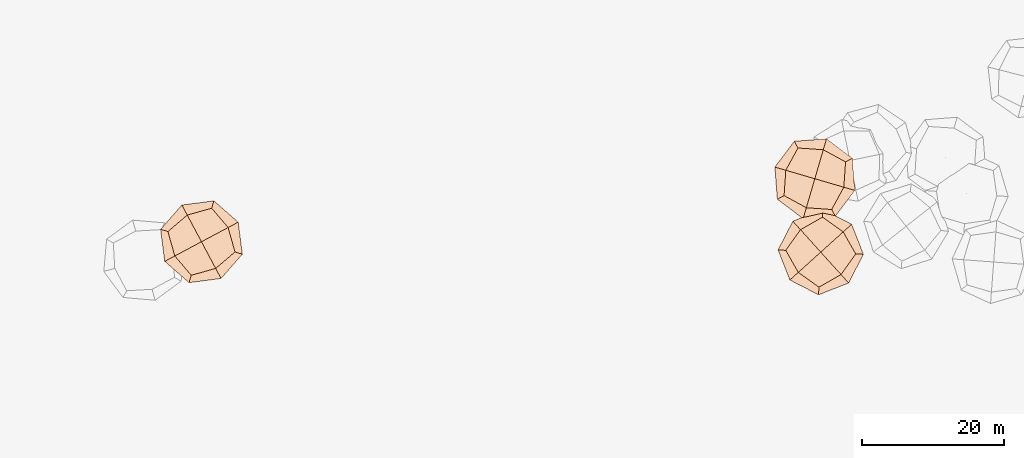
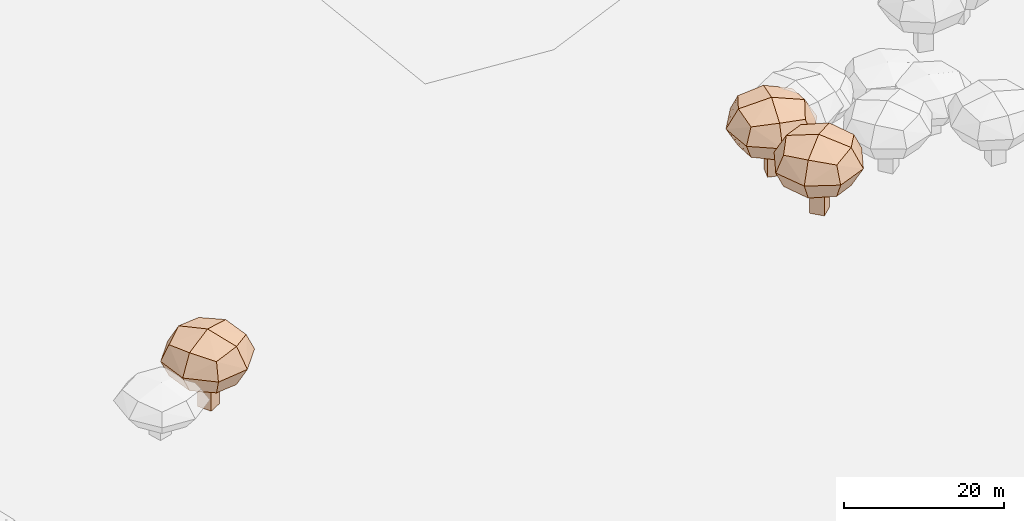
# Not in any storey, part 17 of 92: 3 geographic elements.
"""IFC4 model written with IfcOpenShell, lengths in metres."""

from ifc_helpers import new_model, si_unit, origin_with_axes, place, context, subcontext, project, spatial, triangles, material, element, save


model = new_model("IFC4")

# Units and contexts
model_context = context("Model", 3, precision=1e-05, world=origin_with_axes())
body_context = subcontext(model_context, "Body", "Model", "MODEL_VIEW")
ifc_project = project(units=[si_unit("VOLUMEUNIT", "CUBIC_METRE"), si_unit("LENGTHUNIT", "METRE"), si_unit("AREAUNIT", "SQUARE_METRE")], contexts=[model_context])

# Site
site_placement = place(None, origin_with_axes())
site = spatial("IfcSite", under=ifc_project, at=site_placement)

# Geographic elements
ifc_material = material(Name="tree")
geographic_element_1_placement = place(site_placement, origin_with_axes())
element("IfcGeographicElement", 1, at=geographic_element_1_placement, inside=site, material=ifc_material, Name="cw_instances_tree_210", context=body_context, shape_type="Tessellation", body=[
    triangles([(96.89313110909653, -613.986359858615, 6.803633015926556), (96.89313110909653, -613.986359858615, 6.803633015926556), (96.89313110909653, -613.986359858615, 6.803633015926556), (96.89313110909653, -613.986359858615, 0.0), (96.89313110909653, -613.986359858615, 0.0), (96.89313110909653, -613.986359858615, 0.0), (97.83398614529078, -615.7512371350474, 6.803633015926556), (97.83398614529078, -615.7512371350474, 6.803633015926556), (97.83398614529078, -615.7512371350474, 6.803633015926556), (97.83398614529078, -615.7512371350474, 0.0), (97.83398614529078, -615.7512371350474, 0.0), (97.83398614529078, -615.7512371350474, 0.0), (95.128253832664, -614.9272148948091, 6.803633015926556), (95.128253832664, -614.9272148948091, 6.803633015926556), (95.128253832664, -614.9272148948091, 6.803633015926556), (95.128253832664, -614.9272148948091, 0.0), (95.128253832664, -614.9272148948091, 0.0), (95.128253832664, -614.9272148948091, 0.0), (96.06910886885825, -616.6920921712417, 6.803633015926556), (96.06910886885825, -616.6920921712417, 6.803633015926556), (96.06910886885825, -616.6920921712417, 6.803633015926556), (96.06910886885825, -616.6920921712417, 0.0), (96.06910886885825, -616.6920921712417, 0.0), (96.06910886885825, -616.6920921712417, 0.0), (97.70365412297164, -610.721212612114, 10.134455139926406), (97.70365412297164, -610.721212612114, 10.134455139926406), (97.70365412297164, -610.721212612114, 10.134455139926406), (97.70365412297164, -610.721212612114, 10.134455139926406), (97.70365412297164, -610.721212612114, 10.134455139926406), (97.70365412297164, -610.721212612114, 10.134455139926406), (97.70365410895171, -610.7212120756408, 5.371912219279553), (97.70365410895171, -610.7212120756408, 5.371912219279553), (97.70365410895171, -610.7212120756408, 5.371912219279553), (97.70365410895171, -610.7212120756408, 5.371912219279553), (97.70365410895171, -610.7212120756408, 5.371912219279553), (97.70365410895171, -610.7212120756408, 5.371912219279553), (100.99664617582285, -616.8982814930527, 10.134455139926406), (100.99664617582285, -616.8982814930527, 10.134455139926406), (100.99664617582285, -616.8982814930527, 10.134455139926406), (100.99664617582285, -616.8982814930527, 10.134455139926406), (100.99664617582285, -616.8982814930527, 10.134455139926406), (100.99664617582285, -616.8982814930527, 10.134455139926406), (100.99664617582285, -616.8982814930527, 5.371912219279553), (100.99664617582285, -616.8982814930527, 5.371912219279553), (100.99664617582285, -616.8982814930527, 5.371912219279553), (100.99664617582285, -616.8982814930527, 5.371912219279553), (100.99664617582285, -616.8982814930527, 5.371912219279553), (100.99664617582285, -616.8982814930527, 5.371912219279553), (91.526584056184, -614.0142044812197, 10.134455139926406), (91.526584056184, -614.0142044812197, 10.134455139926406), (91.526584056184, -614.0142044812197, 10.134455139926406), (91.526584056184, -614.0142044812197, 10.134455139926406), (91.526584056184, -614.0142044812197, 10.134455139926406), (91.526584056184, -614.0142044812197, 10.134455139926406), (91.52658447975455, -614.0142042554146, 5.371912219279553), (91.52658447975455, -614.0142042554146, 5.371912219279553), (91.52658447975455, -614.0142042554146, 5.371912219279553), (91.52658447975455, -614.0142042554146, 5.371912219279553), (91.52658447975455, -614.0142042554146, 5.371912219279553), (91.52658447975455, -614.0142042554146, 5.371912219279553), (94.81957623595774, -620.1912741104169, 10.134455139926406), (94.81957623595774, -620.1912741104169, 10.134455139926406), (94.81957623595774, -620.1912741104169, 10.134455139926406), (94.81957623595774, -620.1912741104169, 10.134455139926406), (94.81957623595774, -620.1912741104169, 10.134455139926406), (94.81957623595774, -620.1912741104169, 10.134455139926406), (94.81957612305514, -620.1912738986316, 5.371912219279553), (94.81957612305514, -620.1912738986316, 5.371912219279553), (94.81957612305514, -620.1912738986316, 5.371912219279553), (94.81957612305514, -620.1912738986316, 5.371912219279553), (94.81957612305514, -620.1912738986316, 5.371912219279553), (94.81957612305514, -620.1912738986316, 5.371912219279553), (92.49627184917647, -617.4635454171133, 4.850091157058233), (92.49627184917647, -617.4635454171133, 4.850091157058233), (92.49627184917647, -617.4635454171133, 4.850091157058233), (92.49627184917647, -617.4635454171133, 4.850091157058233), (94.2543131135932, -611.6909001609754, 4.850091157058233), (94.2543131135932, -611.6909001609754, 4.850091157058233), (94.2543131135932, -611.6909001609754, 4.850091157058233), (94.2543131135932, -611.6909001609754, 4.850091157058233), (98.01965599829637, -609.6835980876934, 7.753184087820984), (98.01965599829637, -609.6835980876934, 7.753184087820984), (98.01965599829637, -609.6835980876934, 7.753184087820984), (98.01965599829637, -609.6835980876934, 7.753184087820984), (94.50357393186692, -621.2288883194652, 7.753184087820984), (94.50357393186692, -621.2288883194652, 7.753184087820984), (94.50357393186692, -621.2288883194652, 7.753184087820984), (94.50357393186692, -621.2288883194652, 7.753184087820984), (102.03426081363722, -617.2142841125158, 7.753184087820984), (102.03426081363722, -617.2142841125158, 7.753184087820984), (102.03426081363722, -617.2142841125158, 7.753184087820984), (102.03426081363722, -617.2142841125158, 7.753184087820984), (90.4889701759437, -613.6982022624829, 7.753184087820984), (90.4889701759437, -613.6982022624829, 7.753184087820984), (90.4889701759437, -613.6982022624829, 7.753184087820984), (90.4889701759437, -613.6982022624829, 7.753184087820984), (98.26891751418789, -619.2215864068986, 10.65627579392972), (98.26891751418789, -619.2215864068986, 10.65627579392972), (98.26891751418789, -619.2215864068986, 10.65627579392972), (98.26891751418789, -619.2215864068986, 10.65627579392972), (100.02695846280307, -613.4489407071737, 10.656277392783574), (100.02695846280307, -613.4489407071737, 10.656277392783574), (100.02695846280307, -613.4489407071737, 10.656277392783574), (100.02695846280307, -613.4489407071737, 10.656277392783574), (98.26891724896502, -619.2215860156738, 4.850091157058233), (98.26891724896502, -619.2215860156738, 4.850091157058233), (98.26891724896502, -619.2215860156738, 4.850091157058233), (98.26891724896502, -619.2215860156738, 4.850091157058233), (92.49627183035936, -617.4635453818157, 10.65627579392972), (92.49627183035936, -617.4635453818157, 10.65627579392972), (92.49627183035936, -617.4635453818157, 10.65627579392972), (92.49627183035936, -617.4635453818157, 10.65627579392972), (94.25431314006636, -611.6909001468625, 10.656277392783574), (94.25431314006636, -611.6909001468625, 10.656277392783574), (94.25431314006636, -611.6909001468625, 10.656277392783574), (94.25431314006636, -611.6909001468625, 10.656277392783574), (100.02695807628255, -613.448940981221, 4.850091157058233), (100.02695807628255, -613.448940981221, 4.850091157058233), (100.02695807628255, -613.448940981221, 4.850091157058233), (100.02695807628255, -613.448940981221, 4.850091157058233), (96.26161505982873, -615.4562429774202, 11.751368865324931), (96.26161505982873, -615.4562429774202, 11.751368865324931), (96.26161505982873, -615.4562429774202, 11.751368865324931), (96.26161505982873, -615.4562429774202, 11.751368865324931), (96.26161505982873, -615.4562429774202, 11.751368865324931), (96.26161505982873, -615.4562429774202, 11.751368865324931), (96.26161505982873, -615.4562429774202, 11.751368865324931), (96.26161505982873, -615.4562429774202, 11.751368865324931), (99.02610242428254, -620.6419310832572, 7.753184087820984), (99.02610242428254, -620.6419310832572, 7.753184087820984), (99.02610242428254, -620.6419310832572, 7.753184087820984), (99.02610242428254, -620.6419310832572, 7.753184087820984), (99.02610242428254, -620.6419310832572, 7.753184087820984), (99.02610242428254, -620.6419310832572, 7.753184087820984), (99.02610242428254, -620.6419310832572, 7.753184087820984), (99.02610242428254, -620.6419310832572, 7.753184087820984), (91.07592715870507, -618.2207303007348, 7.753184087820984), (91.07592715870507, -618.2207303007348, 7.753184087820984), (91.07592715870507, -618.2207303007348, 7.753184087820984), (91.07592715870507, -618.2207303007348, 7.753184087820984), (91.07592715870507, -618.2207303007348, 7.753184087820984), (91.07592715870507, -618.2207303007348, 7.753184087820984), (91.07592715870507, -618.2207303007348, 7.753184087820984), (91.07592715870507, -618.2207303007348, 7.753184087820984), (96.26161518337014, -615.4562429115603, 3.7550000927348814), (96.26161518337014, -615.4562429115603, 3.7550000927348814), (96.26161518337014, -615.4562429115603, 3.7550000927348814), (96.26161518337014, -615.4562429115603, 3.7550000927348814), (96.26161518337014, -615.4562429115603, 3.7550000927348814), (96.26161518337014, -615.4562429115603, 3.7550000927348814), (96.26161518337014, -615.4562429115603, 3.7550000927348814), (96.26161518337014, -615.4562429115603, 3.7550000927348814), (101.44730269148555, -612.6917559564093, 7.753184087820984), (101.44730269148555, -612.6917559564093, 7.753184087820984), (101.44730269148555, -612.6917559564093, 7.753184087820984), (101.44730269148555, -612.6917559564093, 7.753184087820984), (101.44730269148555, -612.6917559564093, 7.753184087820984), (101.44730269148555, -612.6917559564093, 7.753184087820984), (101.44730269148555, -612.6917559564093, 7.753184087820984), (101.44730269148555, -612.6917559564093, 7.753184087820984), (93.4971279335714, -610.2705550845676, 7.753184087820984), (93.4971279335714, -610.2705550845676, 7.753184087820984), (93.4971279335714, -610.2705550845676, 7.753184087820984), (93.4971279335714, -610.2705550845676, 7.753184087820984), (93.4971279335714, -610.2705550845676, 7.753184087820984), (93.4971279335714, -610.2705550845676, 7.753184087820984), (93.4971279335714, -610.2705550845676, 7.753184087820984), (93.4971279335714, -610.2705550845676, 7.753184087820984)], [[15, 8, 2], [7, 24, 11], [19, 16, 22], [4, 23, 17], [3, 12, 6], [14, 5, 18], [26, 127, 101], [54, 123, 114], [124, 66, 98], [128, 38, 102], [45, 133, 108], [40, 135, 89], [130, 63, 88], [131, 70, 105], [68, 141, 73], [61, 140, 86], [137, 49, 93], [142, 56, 74], [59, 145, 75], [31, 149, 79], [150, 43, 107], [146, 71, 76], [35, 154, 120], [30, 157, 83], [158, 42, 91], [153, 47, 119], [58, 164, 77], [51, 162, 96], [167, 28, 81], [165, 33, 80], [15, 21, 8], [7, 20, 24], [19, 13, 16], [4, 10, 23], [3, 9, 12], [14, 1, 5], [25, 115, 126], [53, 111, 121], [122, 112, 65], [125, 99, 37], [46, 90, 136], [39, 100, 134], [132, 97, 64], [129, 87, 69], [67, 85, 138], [62, 110, 144], [143, 109, 50], [139, 94, 55], [60, 78, 147], [32, 117, 151], [152, 118, 44], [148, 106, 72], [36, 84, 160], [29, 104, 156], [155, 103, 41], [159, 92, 48], [57, 95, 161], [52, 113, 163], [166, 116, 27], [168, 82, 34]], closed=True),
])
geographic_element_2_placement = place(site_placement, origin_with_axes())
element("IfcGeographicElement", 2, at=geographic_element_2_placement, inside=site, material=ifc_material, Name="cw_instances_tree_223", context=body_context, shape_type="Tessellation", body=[
    triangles([(184.33929318169518, -605.949848774874, 6.6146747117535885), (184.33929318169518, -605.949848774874, 6.6146747117535885), (184.33929318169518, -605.949848774874, 6.6146747117535885), (184.33929318169518, -605.949848774874, 0.0), (184.33929318169518, -605.949848774874, 0.0), (184.33929318169518, -605.949848774874, 0.0), (183.77831863998094, -607.8695642651352, 6.6146747117535885), (183.77831863998094, -607.8695642651352, 6.6146747117535885), (183.77831863998094, -607.8695642651352, 6.6146747117535885), (183.77831863998094, -607.8695642651352, 0.0), (183.77831863998094, -607.8695642651352, 0.0), (183.77831863998094, -607.8695642651352, 0.0), (182.41957769143406, -605.3888742331599, 6.6146747117535885), (182.41957769143406, -605.3888742331599, 6.6146747117535885), (182.41957769143406, -605.3888742331599, 6.6146747117535885), (182.41957769143406, -605.3888742331599, 0.0), (182.41957769143406, -605.3888742331599, 0.0), (182.41957769143406, -605.3888742331599, 0.0), (181.8586031497198, -607.3085897234209, 6.6146747117535885), (181.8586031497198, -607.3085897234209, 6.6146747117535885), (181.8586031497198, -607.3085897234209, 6.6146747117535885), (181.8586031497198, -607.3085897234209, 0.0), (181.8586031497198, -607.3085897234209, 0.0), (181.8586031497198, -607.3085897234209, 0.0), (187.2013929023702, -604.1816521550759, 9.852989421173685), (187.2013929023702, -604.1816521550759, 9.852989421173685), (187.2013929023702, -604.1816521550759, 9.852989421173685), (187.2013929023702, -604.1816521550759, 9.852989421173685), (187.2013929023702, -604.1816521550759, 9.852989421173685), (187.2013929023702, -604.1816521550759, 9.852989421173685), (187.20139326736995, -604.1816517616611, 5.222717308157076), (187.20139326736995, -604.1816517616611, 5.222717308157076), (187.20139326736995, -604.1816517616611, 5.222717308157076), (187.20139326736995, -604.1816517616611, 5.222717308157076), (187.20139326736995, -604.1816517616611, 5.222717308157076), (187.20139326736995, -604.1816517616611, 5.222717308157076), (185.23798270515005, -610.9006548353443, 9.852989421173685), (185.23798270515005, -610.9006548353443, 9.852989421173685), (185.23798270515005, -610.9006548353443, 9.852989421173685), (185.23798270515005, -610.9006548353443, 9.852989421173685), (185.23798270515005, -610.9006548353443, 9.852989421173685), (185.23798270515005, -610.9006548353443, 9.852989421173685), (185.23798270515005, -610.9006548353443, 5.222717308157076), (185.23798270515005, -610.9006548353443, 5.222717308157076), (185.23798270515005, -610.9006548353443, 5.222717308157076), (185.23798270515005, -610.9006548353443, 5.222717308157076), (185.23798270515005, -610.9006548353443, 5.222717308157076), (185.23798270515005, -610.9006548353443, 5.222717308157076), (180.48238950258914, -602.2182409974904, 9.852989421173685), (180.48238950258914, -602.2182409974904, 9.852989421173685), (180.48238950258914, -602.2182409974904, 9.852989421173685), (180.48238950258914, -602.2182409974904, 9.852989421173685), (180.48238950258914, -602.2182409974904, 9.852989421173685), (180.48238950258914, -602.2182409974904, 9.852989421173685), (180.48238996332088, -602.2182411321243, 5.222717308157076), (180.48238996332088, -602.2182411321243, 5.222717308157076), (180.48238996332088, -602.2182411321243, 5.222717308157076), (180.48238996332088, -602.2182411321243, 5.222717308157076), (180.48238996332088, -602.2182411321243, 5.222717308157076), (180.48238996332088, -602.2182411321243, 5.222717308157076), (178.51897887305228, -608.9372443015394, 9.852989421173685), (178.51897887305228, -608.9372443015394, 9.852989421173685), (178.51897887305228, -608.9372443015394, 9.852989421173685), (178.51897887305228, -608.9372443015394, 9.852989421173685), (178.51897887305228, -608.9372443015394, 9.852989421173685), (178.51897887305228, -608.9372443015394, 9.852989421173685), (178.51897894036924, -608.9372440711736, 5.222717308157076), (178.51897894036924, -608.9372440711736, 5.222717308157076), (178.51897894036924, -608.9372440711736, 5.222717308157076), (178.51897894036924, -608.9372440711736, 5.222717308157076), (178.51897894036924, -608.9372440711736, 5.222717308157076), (178.51897894036924, -608.9372440711736, 5.222717308157076), (178.76449736633052, -605.3626159617861, 4.715388859333372), (178.76449736633052, -605.3626159617861, 4.715388859333372), (178.76449736633052, -605.3626159617861, 4.715388859333372), (178.76449736633052, -605.3626159617861, 4.715388859333372), (184.05701805618915, -602.4637597928771, 4.715388859333372), (184.05701805618915, -602.4637597928771, 4.715388859333372), (184.05701805618915, -602.4637597928771, 4.715388859333372), (184.05701805618915, -602.4637597928771, 4.715388859333372), (188.1527062711343, -603.6605917354432, 7.537853761545888), (188.1527062711343, -603.6605917354432, 7.537853761545888), (188.1527062711343, -603.6605917354432, 7.537853761545888), (188.1527062711343, -603.6605917354432, 7.537853761545888), (177.5676654181548, -609.4583041959283, 7.537853761545888), (177.5676654181548, -609.4583041959283, 7.537853761545888), (177.5676654181548, -609.4583041959283, 7.537853761545888), (177.5676654181548, -609.4583041959283, 7.537853761545888), (185.7590426856724, -611.8519688154856, 7.537853761545888), (185.7590426856724, -611.8519688154856, 7.537853761545888), (185.7590426856724, -611.8519688154856, 7.537853761545888), (185.7590426856724, -611.8519688154856, 7.537853761545888), (179.96132978365256, -601.266927833482, 7.537853761545888), (179.96132978365256, -601.266927833482, 7.537853761545888), (179.96132978365256, -601.266927833482, 7.537853761545888), (179.96132978365256, -601.266927833482, 7.537853761545888), (181.66335401959412, -610.6551367410906, 10.360317473116883), (181.66335401959412, -610.6551367410906, 10.360317473116883), (181.66335401959412, -610.6551367410906, 10.360317473116883), (181.66335401959412, -610.6551367410906, 10.360317473116883), (186.95587479372583, -607.7562800342243, 10.360319027565533), (186.95587479372583, -607.7562800342243, 10.360319027565533), (186.95587479372583, -607.7562800342243, 10.360319027565533), (186.95587479372583, -607.7562800342243, 10.360319027565533), (181.66335410343024, -610.6551362759332, 4.715388859333372), (181.66335410343024, -610.6551362759332, 4.715388859333372), (181.66335410343024, -610.6551362759332, 4.715388859333372), (181.66335410343024, -610.6551362759332, 4.715388859333372), (178.76449737755001, -605.3626159233918, 10.360317473116883), (178.76449737755001, -605.3626159233918, 10.360317473116883), (178.76449737755001, -605.3626159233918, 10.360317473116883), (178.76449737755001, -605.3626159233918, 10.360317473116883), (184.0570180849849, -602.4637598012918, 10.360319027565533), (184.0570180849849, -602.4637598012918, 10.360319027565533), (184.0570180849849, -602.4637598012918, 10.360319027565533), (184.0570180849849, -602.4637598012918, 10.360319027565533), (186.95587432576346, -607.7562799599868, 4.715388859333372), (186.95587432576346, -607.7562799599868, 4.715388859333372), (186.95587432576346, -607.7562799599868, 4.715388859333372), (186.95587432576346, -607.7562799599868, 4.715388859333372), (182.86018607049306, -606.5594478702004, 11.424996362971436), (182.86018607049306, -606.5594478702004, 11.424996362971436), (182.86018607049306, -606.5594478702004, 11.424996362971436), (182.86018607049306, -606.5594478702004, 11.424996362971436), (182.86018607049306, -606.5594478702004, 11.424996362971436), (182.86018607049306, -606.5594478702004, 11.424996362971436), (182.86018607049306, -606.5594478702004, 11.424996362971436), (182.86018607049306, -606.5594478702004, 11.424996362971436), (181.2118907849906, -612.2000927066562, 7.537853761545888), (181.2118907849906, -612.2000927066562, 7.537853761545888), (181.2118907849906, -612.2000927066562, 7.537853761545888), (181.2118907849906, -612.2000927066562, 7.537853761545888), (181.2118907849906, -612.2000927066562, 7.537853761545888), (181.2118907849906, -612.2000927066562, 7.537853761545888), (181.2118907849906, -612.2000927066562, 7.537853761545888), (181.2118907849906, -612.2000927066562, 7.537853761545888), (177.2195414091796, -604.9111526983869, 7.537853761545888), (177.2195414091796, -604.9111526983869, 7.537853761545888), (177.2195414091796, -604.9111526983869, 7.537853761545888), (177.2195414091796, -604.9111526983869, 7.537853761545888), (177.2195414091796, -604.9111526983869, 7.537853761545888), (177.2195414091796, -604.9111526983869, 7.537853761545888), (177.2195414091796, -604.9111526983869, 7.537853761545888), (177.2195414091796, -604.9111526983869, 7.537853761545888), (182.86018620487314, -606.5594479094686, 3.650711920807976), (182.86018620487314, -606.5594479094686, 3.650711920807976), (182.86018620487314, -606.5594479094686, 3.650711920807976), (182.86018620487314, -606.5594479094686, 3.650711920807976), (182.86018620487314, -606.5594479094686, 3.650711920807976), (182.86018620487314, -606.5594479094686, 3.650711920807976), (182.86018620487314, -606.5594479094686, 3.650711920807976), (182.86018620487314, -606.5594479094686, 3.650711920807976), (188.50083032779233, -608.2077430698089, 7.537853761545888), (188.50083032779233, -608.2077430698089, 7.537853761545888), (188.50083032779233, -608.2077430698089, 7.537853761545888), (188.50083032779233, -608.2077430698089, 7.537853761545888), (188.50083032779233, -608.2077430698089, 7.537853761545888), (188.50083032779233, -608.2077430698089, 7.537853761545888), (188.50083032779233, -608.2077430698089, 7.537853761545888), (188.50083032779233, -608.2077430698089, 7.537853761545888), (184.50848137743367, -600.9188033525555, 7.537853761545888), (184.50848137743367, -600.9188033525555, 7.537853761545888), (184.50848137743367, -600.9188033525555, 7.537853761545888), (184.50848137743367, -600.9188033525555, 7.537853761545888), (184.50848137743367, -600.9188033525555, 7.537853761545888), (184.50848137743367, -600.9188033525555, 7.537853761545888), (184.50848137743367, -600.9188033525555, 7.537853761545888), (184.50848137743367, -600.9188033525555, 7.537853761545888)], [[15, 8, 2], [7, 24, 11], [19, 16, 22], [4, 23, 17], [3, 12, 6], [14, 5, 18], [26, 127, 101], [54, 123, 114], [124, 66, 98], [128, 38, 102], [45, 133, 108], [40, 135, 89], [130, 63, 88], [131, 70, 105], [68, 141, 73], [61, 140, 86], [137, 49, 93], [142, 56, 74], [59, 145, 75], [31, 149, 79], [150, 43, 107], [146, 71, 76], [35, 154, 120], [30, 157, 83], [158, 42, 91], [153, 47, 119], [58, 164, 77], [51, 162, 96], [167, 28, 81], [165, 33, 80], [15, 21, 8], [7, 20, 24], [19, 13, 16], [4, 10, 23], [3, 9, 12], [14, 1, 5], [25, 115, 126], [53, 111, 121], [122, 112, 65], [125, 99, 37], [46, 90, 136], [39, 100, 134], [132, 97, 64], [129, 87, 69], [67, 85, 138], [62, 110, 144], [143, 109, 50], [139, 94, 55], [60, 78, 147], [32, 117, 151], [152, 118, 44], [148, 106, 72], [36, 84, 160], [29, 104, 156], [155, 103, 41], [159, 92, 48], [57, 95, 161], [52, 113, 163], [166, 116, 27], [168, 82, 34]], closed=True),
])
geographic_element_3_placement = place(site_placement, origin_with_axes())
element("IfcGeographicElement", 3, at=geographic_element_3_placement, inside=site, material=ifc_material, Name="cw_instances_tree_224", context=body_context, shape_type="Tessellation", body=[
    triangles([(183.95356099233993, -615.3406794834362, 6.807676790608029), (183.95356099233993, -615.3406794834362, 6.807676790608029), (183.95356099233993, -615.3406794834362, 6.807676790608029), (183.95356099233993, -615.3406794834362, 0.0), (183.95356099233993, -615.3406794834362, 0.0), (183.95356099233993, -615.3406794834362, 0.0), (185.2934664279831, -616.8254870209756, 6.807676790608029), (185.2934664279831, -616.8254870209756, 6.807676790608029), (185.2934664279831, -616.8254870209756, 6.807676790608029), (185.2934664279831, -616.8254870209756, 0.0), (185.2934664279831, -616.8254870209756, 0.0), (185.2934664279831, -616.8254870209756, 0.0), (182.4687534548005, -616.6805849190794, 6.807676790608029), (182.4687534548005, -616.6805849190794, 6.807676790608029), (182.4687534548005, -616.6805849190794, 6.807676790608029), (182.4687534548005, -616.6805849190794, 0.0), (182.4687534548005, -616.6805849190794, 0.0), (182.4687534548005, -616.6805849190794, 0.0), (183.80865889044367, -618.1653924566189, 6.807676790608029), (183.80865889044367, -618.1653924566189, 6.807676790608029), (183.80865889044367, -618.1653924566189, 6.807676790608029), (183.80865889044367, -618.1653924566189, 0.0), (183.80865889044367, -618.1653924566189, 0.0), (183.80865889044367, -618.1653924566189, 0.0), (183.95001728328072, -611.9764378839848, 10.14047860606713), (183.95001728328072, -611.9764378839848, 10.14047860606713), (183.95001728328072, -611.9764378839848, 10.14047860606713), (183.95001728328072, -611.9764378839848, 10.14047860606713), (183.95001728328072, -611.9764378839848, 10.14047860606713), (183.95001728328072, -611.9764378839848, 10.14047860606713), (183.95001713988032, -611.9764373668423, 5.375105043256473), (183.95001713988032, -611.9764373668423, 5.375105043256473), (183.95001713988032, -611.9764373668423, 5.375105043256473), (183.95001713988032, -611.9764373668423, 5.375105043256473), (183.95001713988032, -611.9764373668423, 5.375105043256473), (183.95001713988032, -611.9764373668423, 5.375105043256473), (188.6396853673877, -617.1732628647698, 10.14047860606713), (188.6396853673877, -617.1732628647698, 10.14047860606713), (188.6396853673877, -617.1732628647698, 10.14047860606713), (188.6396853673877, -617.1732628647698, 10.14047860606713), (188.6396853673877, -617.1732628647698, 10.14047860606713), (188.6396853673877, -617.1732628647698, 10.14047860606713), (188.6396853673877, -617.1732628647698, 5.375105043256473), (188.6396853673877, -617.1732628647698, 5.375105043256473), (188.6396853673877, -617.1732628647698, 5.375105043256473), (188.6396853673877, -617.1732628647698, 5.375105043256473), (188.6396853673877, -617.1732628647698, 5.375105043256473), (188.6396853673877, -617.1732628647698, 5.375105043256473), (178.75319110742214, -616.6661060767157, 10.14047860606713), (178.75319110742214, -616.6661060767157, 10.14047860606713), (178.75319110742214, -616.6661060767157, 10.14047860606713), (178.75319110742214, -616.6661060767157, 10.14047860606713), (178.75319110742214, -616.6661060767157, 10.14047860606713), (178.75319110742214, -616.6661060767157, 10.14047860606713), (178.75319146377595, -616.6661057551383, 5.375105043256473), (178.75319146377595, -616.6661057551383, 5.375105043256473), (178.75319146377595, -616.6661057551383, 5.375105043256473), (178.75319146377595, -616.6661057551383, 5.375105043256473), (178.75319146377595, -616.6661057551383, 5.375105043256473), (178.75319146377595, -616.6661057551383, 5.375105043256473), (183.44285949571815, -621.86293175282, 10.14047860606713), (183.44285949571815, -621.86293175282, 10.14047860606713), (183.44285949571815, -621.86293175282, 10.14047860606713), (183.44285949571815, -621.86293175282, 10.14047860606713), (183.44285949571815, -621.86293175282, 10.14047860606713), (183.44285949571815, -621.86293175282, 10.14047860606713), (183.4428593349295, -621.8629315746431, 5.375105043256473), (183.4428593349295, -621.8629315746431, 5.375105043256473), (183.4428593349295, -621.8629315746431, 5.375105043256473), (183.4428593349295, -621.8629315746431, 5.375105043256473), (183.4428593349295, -621.8629315746431, 5.375105043256473), (183.4428593349295, -621.8629315746431, 5.375105043256473), (180.5286202404596, -619.7783558580588, 4.852973833971852), (180.5286202404596, -619.7783558580588, 4.852973833971852), (180.5286202404596, -619.7783558580588, 4.852973833971852), (180.5286202404596, -619.7783558580588, 4.852973833971852), (180.8377673715695, -613.7518667979236, 4.852973833971852), (180.8377673715695, -613.7518667979236, 4.852973833971852), (180.8377673715695, -613.7518667979236, 4.852973833971852), (180.8377673715695, -613.7518667979236, 4.852973833971852), (184.00558508404453, -610.8931958491581, 7.7577922331224345), (184.00558508404453, -610.8931958491581, 7.7577922331224345), (184.00558508404453, -610.8931958491581, 7.7577922331224345), (184.00558508404453, -610.8931958491581, 7.7577922331224345), (183.38729120262417, -622.946173585382, 7.7577922331224345), (183.38729120262417, -622.946173585382, 7.7577922331224345), (183.38729120262417, -622.946173585382, 7.7577922331224345), (183.38729120262417, -622.946173585382, 7.7577922331224345), (189.72292769227985, -617.2288313601284, 7.7577922331224345), (189.72292769227985, -617.2288313601284, 7.7577922331224345), (189.72292769227985, -617.2288313601284, 7.7577922331224345), (189.72292769227985, -617.2288313601284, 7.7577922331224345), (177.66994961455023, -616.6105377868863, 7.7577922331224345), (177.66994961455023, -616.6105377868863, 7.7577922331224345), (177.66994961455023, -616.6105377868863, 7.7577922331224345), (177.66994961455023, -616.6105377868863, 7.7577922331224345), (186.55510963087502, -620.0875026237718, 10.66260940689112), (186.55510963087502, -620.0875026237718, 10.66260940689112), (186.55510963087502, -620.0875026237718, 10.66260940689112), (186.55510963087502, -620.0875026237718, 10.66260940689112), (186.8642563482422, -614.0610132096351, 10.662611006695261), (186.8642563482422, -614.0610132096351, 10.662611006695261), (186.8642563482422, -614.0610132096351, 10.662611006695261), (186.8642563482422, -614.0610132096351, 10.662611006695261), (186.55510927887707, -620.0875023083396, 4.852973833971852), (186.55510927887707, -620.0875023083396, 4.852973833971852), (186.55510927887707, -620.0875023083396, 4.852973833971852), (186.55510927887707, -620.0875023083396, 4.852973833971852), (180.52862021366147, -619.7783558283627, 10.66260940689112), (180.52862021366147, -619.7783558283627, 10.66260940689112), (180.52862021366147, -619.7783558283627, 10.66260940689112), (180.52862021366147, -619.7783558283627, 10.66260940689112), (180.8377673938416, -613.7518667778251, 10.662611006695261), (180.8377673938416, -613.7518667778251, 10.662611006695261), (180.8377673938416, -613.7518667778251, 10.662611006695261), (180.8377673938416, -613.7518667778251, 10.662611006695261), (186.8642560395096, -614.0610135690572, 4.852973833971852), (186.8642560395096, -614.0610135690572, 4.852973833971852), (186.8642560395096, -614.0610135690572, 4.852973833971852), (186.8642560395096, -614.0610135690572, 4.852973833971852), (183.6964381805484, -616.9196844749064, 11.758353352550948), (183.6964381805484, -616.9196844749064, 11.758353352550948), (183.6964381805484, -616.9196844749064, 11.758353352550948), (183.6964381805484, -616.9196844749064, 11.758353352550948), (183.6964381805484, -616.9196844749064, 11.758353352550948), (183.6964381805484, -616.9196844749064, 11.758353352550948), (183.6964381805484, -616.9196844749064, 11.758353352550948), (183.6964381805484, -616.9196844749064, 11.758353352550948), (187.63344384581072, -621.2824517057975, 7.7577922331224345), (187.63344384581072, -621.2824517057975, 7.7577922331224345), (187.63344384581072, -621.2824517057975, 7.7577922331224345), (187.63344384581072, -621.2824517057975, 7.7577922331224345), (187.63344384581072, -621.2824517057975, 7.7577922331224345), (187.63344384581072, -621.2824517057975, 7.7577922331224345), (187.63344384581072, -621.2824517057975, 7.7577922331224345), (187.63344384581072, -621.2824517057975, 7.7577922331224345), (179.33367113833523, -620.8566900507225, 7.7577922331224345), (179.33367113833523, -620.8566900507225, 7.7577922331224345), (179.33367113833523, -620.8566900507225, 7.7577922331224345), (179.33367113833523, -620.8566900507225, 7.7577922331224345), (179.33367113833523, -620.8566900507225, 7.7577922331224345), (179.33367113833523, -620.8566900507225, 7.7577922331224345), (179.33367113833523, -620.8566900507225, 7.7577922331224345), (179.33367113833523, -620.8566900507225, 7.7577922331224345), (183.69643828448494, -616.919684381113, 3.7572318965767972), (183.69643828448494, -616.919684381113, 3.7572318965767972), (183.69643828448494, -616.919684381113, 3.7572318965767972), (183.69643828448494, -616.919684381113, 3.7572318965767972), (183.69643828448494, -616.919684381113, 3.7572318965767972), (183.69643828448494, -616.919684381113, 3.7572318965767972), (183.69643828448494, -616.919684381113, 3.7572318965767972), (183.69643828448494, -616.919684381113, 3.7572318965767972), (188.0592050344415, -612.982679257609, 7.7577922331224345), (188.0592050344415, -612.982679257609, 7.7577922331224345), (188.0592050344415, -612.982679257609, 7.7577922331224345), (188.0592050344415, -612.982679257609, 7.7577922331224345), (188.0592050344415, -612.982679257609, 7.7577922331224345), (188.0592050344415, -612.982679257609, 7.7577922331224345), (188.0592050344415, -612.982679257609, 7.7577922331224345), (188.0592050344415, -612.982679257609, 7.7577922331224345), (179.7594327979363, -612.5569173930417, 7.7577922331224345), (179.7594327979363, -612.5569173930417, 7.7577922331224345), (179.7594327979363, -612.5569173930417, 7.7577922331224345), (179.7594327979363, -612.5569173930417, 7.7577922331224345), (179.7594327979363, -612.5569173930417, 7.7577922331224345), (179.7594327979363, -612.5569173930417, 7.7577922331224345), (179.7594327979363, -612.5569173930417, 7.7577922331224345), (179.7594327979363, -612.5569173930417, 7.7577922331224345)], [[15, 8, 2], [7, 24, 11], [19, 16, 22], [4, 23, 17], [3, 12, 6], [14, 5, 18], [26, 127, 101], [54, 123, 114], [124, 66, 98], [128, 38, 102], [45, 133, 108], [40, 135, 89], [130, 63, 88], [131, 70, 105], [68, 141, 73], [61, 140, 86], [137, 49, 93], [142, 56, 74], [59, 145, 75], [31, 149, 79], [150, 43, 107], [146, 71, 76], [35, 154, 120], [30, 157, 83], [158, 42, 91], [153, 47, 119], [58, 164, 77], [51, 162, 96], [167, 28, 81], [165, 33, 80], [15, 21, 8], [7, 20, 24], [19, 13, 16], [4, 10, 23], [3, 9, 12], [14, 1, 5], [25, 115, 126], [53, 111, 121], [122, 112, 65], [125, 99, 37], [46, 90, 136], [39, 100, 134], [132, 97, 64], [129, 87, 69], [67, 85, 138], [62, 110, 144], [143, 109, 50], [139, 94, 55], [60, 78, 147], [32, 117, 151], [152, 118, 44], [148, 106, 72], [36, 84, 160], [29, 104, 156], [155, 103, 41], [159, 92, 48], [57, 95, 161], [52, 113, 163], [166, 116, 27], [168, 82, 34]], closed=True),
])

save(model, "model.ifc")
